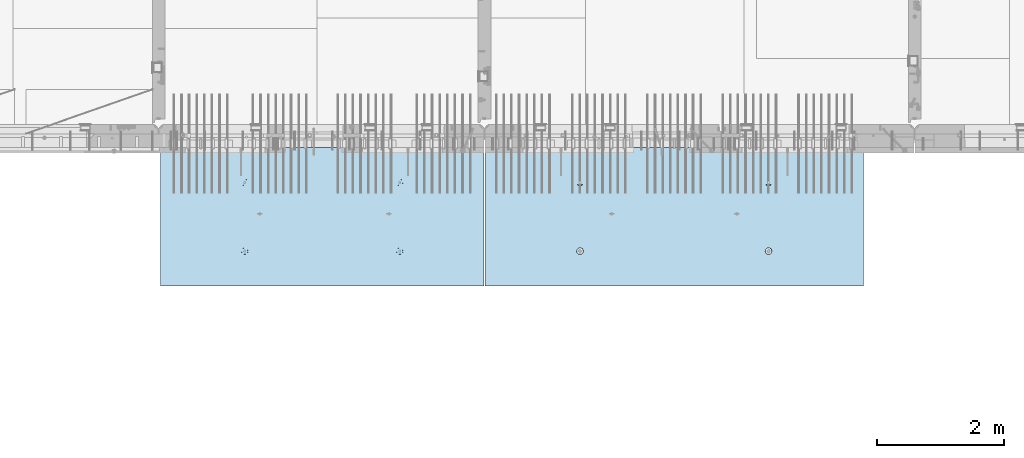
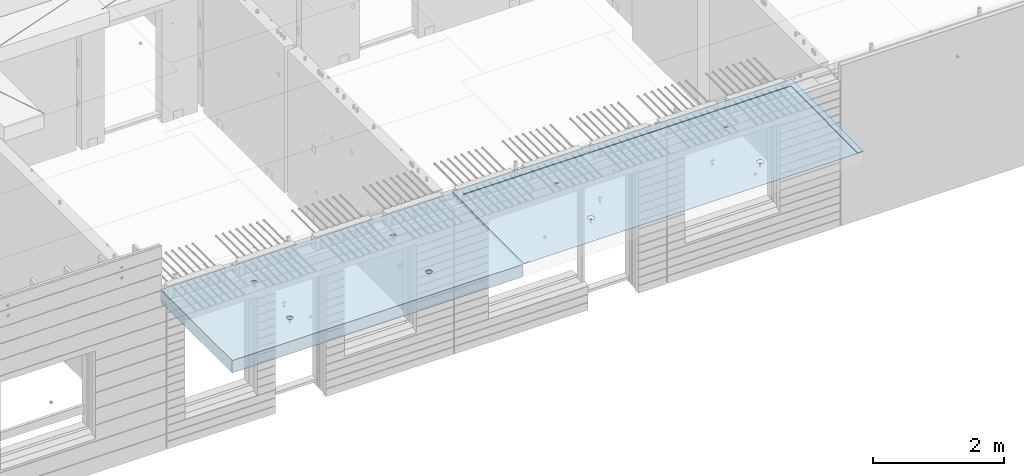
# One storey, part 173 of 309: 2 slabs, 2 elements without a shape of their own.
"""IFC2X3 building model written with IfcOpenShell, lengths in millimetres."""

from ifc_helpers import new_model, si_unit, frame, origin_with_axes, place, context, subcontext, project, spatial, faceted_brep, material, type_object, element, aggregate, save


model = new_model("IFC2X3")

# Units and contexts
model_context = context("Model", 3, precision=1e-05, world=origin_with_axes())
body_context = subcontext(model_context, "Body", "Model", "MODEL_VIEW")
ifc_project = project(units=[si_unit("LENGTHUNIT", "METRE", prefix="MILLI"), si_unit("AREAUNIT", "SQUARE_METRE"), si_unit("VOLUMEUNIT", "CUBIC_METRE"), si_unit("MASSUNIT", "GRAM", prefix="KILO"), si_unit("TIMEUNIT", "SECOND"), si_unit("PLANEANGLEUNIT", "RADIAN"), si_unit("SOLIDANGLEUNIT", "STERADIAN"), si_unit("THERMODYNAMICTEMPERATUREUNIT", "DEGREE_CELSIUS"), si_unit("LUMINOUSINTENSITYUNIT", "LUMEN")], contexts=[model_context])

# Site, building, storey
site_placement = place(None, origin_with_axes())
site = spatial("IfcSite", under=ifc_project, at=site_placement, CompositionType="ELEMENT")
building_placement = place(site_placement, origin_with_axes())
building = spatial("IfcBuilding", under=site, at=building_placement, CompositionType="ELEMENT")
storey_placement = place(building_placement, origin_with_axes())
storey = spatial("IfcBuildingStorey", under=building, at=storey_placement, Name="7", CompositionType="ELEMENT", Elevation=0.0)

# Assembly, slab
assembly_1_placement = place(storey_placement, origin_with_axes())
assembly_1 = element("IfcElementAssembly", 1, at=assembly_1_placement, inside=storey, AssemblyPlace="NOTDEFINED", PredefinedType="REINFORCEMENT_UNIT")
ifc_material = material(Name="CONCRETE/C35/45")
slab_type_1 = type_object("IfcSlabType", PredefinedType="NOTDEFINED")
slab_1_placement = place(assembly_1_placement, frame((21819.9998568014, 7630.00344031289, 102715.0), z_axis=(-1.11800000013248e-06, -0.999999999999375, 0.0), x_axis=(0.999999999999375, -1.11799999997436e-06, 0.0)))
slab_1 = element("IfcSlab", 2, at=slab_1_placement, type_object=slab_type_1, material=ifc_material, PredefinedType="FLOOR", context=body_context, shape_type="Brep", body=[
    faceted_brep([(5979.99951171875, -15.0, 2184.99365234375), (5980.0, -15.0, -9.11677489057183e-09), (5979.99999999881, 14.9999889254686, 0.00267301795884123), (5979.99951171875, -5.00001158128725, 2184.99365234375), (0.0, -15.0, 0.0), (0.0, 15.0, 0.0), (-0.000976578216068447, -15.0, 2184.99365234375), (-0.000976578216068447, -4.99999962141737, 2184.99365234375), (99.9990234070356, -15.0, 2184.99365234375), (99.9990234170364, -4.9999998214189, 2184.99365234375), (100.000169136605, 4.99999899105751, 149.999887195343), (100.000169145234, 13.6270007889543, 149.999887195343), (5880.00017319752, 4.99999608613143, 150.00314992553), (5880.00017320615, 13.626982615926, 150.003149916904), (5879.99902340611, -15.0, 2184.99365234375), (5879.99902341611, -5.00001138128573, 2184.99365234375), (1542.35643735858, -9.29224814563349, 1604.231780609), (1541.83170276904, -15.0, 1604.6130235213), (1549.1758082776, -15.0, 1619.02660112956), (1549.7771641149, -9.43573199193634, 1618.8312080139), (1530.78185465163, -9.17831515427679, 1592.6391402674), (1530.39300293862, -15.0, 1593.17435002456), (1516.18640918342, -9.10513605941378, 1585.19319237956), (1515.97940842387, -15.0, 1585.83027769861), (1500.00182150668, -9.07991502917139, 1582.62695858894), (1500.001822281, -15.0, 1583.29969551145), (1483.81723975291, -9.10513649972563, 1585.19322968407), (1484.02424196357, -15.0, 1585.830314479), (1469.22181146578, -9.17831599155033, 1592.63921119998), (1469.61066435491, -15.0, 1593.17441998503), (1457.64725549508, -9.29224929746124, 1604.23187818621), (1458.17199085636, -15.0, 1604.61311981363), (1450.22656238703, -9.43573334516259, 1618.83132264417), (1450.82791852787, -15.0, 1619.02671432798), (1447.68309567355, -9.59468214913795, 1635.00430118441), (1448.29733633842, -15.0, 1635.00430047201), (1450.2609443985, -9.75352120940806, 1651.16611452994), (1450.82795530481, -15.0, 1650.98188079173), (1457.70289734829, -9.8967179244064, 1665.7363264415), (1458.17206081124, -15.0, 1665.39545840293), (1469.27747998517, -10.0102960024233, 1677.29285448863), (1469.61076064166, -15.0, 1676.8341319033), (1483.85169912509, -10.0831879667385, 1684.70958694994), (1484.02435515854, -15.0, 1684.17820423219), (1500.00194194467, -10.1082993235468, 1687.2646615023), (1500.00194130486, -15.0, 1686.70878642047), (1516.15217889783, -10.0831875282893, 1684.70954981947), (1515.97952162574, -15.0, 1684.17816745179), (1530.72638100472, -10.0102951681765, 1677.29278383764), (1530.39309923654, -15.0, 1676.83406194283), (1542.30093708833, -9.89671677560546, 1665.73622914589), (1541.8317727351, -15.0, 1665.3953621106), (1549.74285653791, -9.75351985805901, 1651.16600007372), (1549.17584506145, -15.0, 1650.98176759331), (1552.32066807389, -9.59468072727032, 1635.00418074657), (1551.70642724745, -15.0, 1635.00418144815), (4522.3564410818, -9.29220762521436, 1604.22834792249), (4521.83170276706, -15.0, 1604.6095935413), (4529.17580827563, -15.0, 1619.02317114956), (4529.77716849079, -9.43569148414826, 1618.82777661145), (4510.78185735683, -9.17827462384594, 1592.63570656128), (4510.39300293665, -15.0, 1593.17092004456), (4496.18641060492, -9.10509552253643, 1585.18975801856), (4495.9794084219, -15.0, 1585.8268477186), (4480.0018215047, -9.0798744900676, 1582.62352400222), (4480.00182227903, -15.0, 1583.29626553145), (4463.81723832746, -9.10509596284828, 1585.18979532306), (4464.0242419616, -15.0, 1585.826884499), (4449.22180875662, -9.17827546110493, 1592.63577749387), (4449.61066435294, -15.0, 1593.17099000503), (4437.64725176791, -9.29220877704211, 1604.2284454997), (4438.17199085438, -15.0, 1604.60968983363), (4430.22655800719, -9.43569283735997, 1618.82789124172), (4430.82791852589, -15.0, 1619.02328434798), (4427.68309107, -9.59464165531972, 1635.00087120442), (4428.29733633644, -15.0, 1635.00087049201), (4430.26094002169, -9.75348072955967, 1651.16268597142), (4430.82795530284, -15.0, 1650.97845081173), (4437.70289362601, -9.89667745715997, 1665.73289916447), (4438.17206080927, -15.0, 1665.39202842292), (4449.27747728091, -10.0102555451595, 1677.28942822802), (4449.61076063968, -15.0, 1676.8307019233), (4463.85169770267, -10.0831475158775, 1684.70616134165), (4464.02435515657, -15.0, 1684.17477425219), (4480.00194194271, -10.1082588749123, 1687.26123611873), (4480.00194130289, -15.0, 1686.70535644047), (4496.15218031632, -10.0831470774283, 1684.70612421118), (4495.97952162377, -15.0, 1684.17473747179), (4510.72638370505, -10.0102547109127, 1677.28935757703), (4510.39309923456, -15.0, 1676.83063196283), (4522.30094080667, -9.89667630834447, 1665.73280186885), (4521.83177273312, -15.0, 1665.3919321306), (4529.74286091078, -9.75347937821061, 1651.16257151518), (4529.17584505948, -15.0, 1650.97833761331), (4532.32067267349, -9.59464023343753, 1635.00075076656), (4531.70642724547, -15.0, 1635.00075146815), (1548.20188836927, -15.0, 534.342642348693), (1549.93108139027, 1.00000001621083, 533.780791293159), (1542.47398964419, 1.00000003085006, 519.145466335593), (1541.00305088176, -15.0, 520.214168473346), (1530.85930981639, 1.00000004246249, 507.530813244751), (1529.79061104799, -15.0, 509.001754452365), (1516.22396769263, 1.00000004991307, 500.073755189214), (1515.66212060056, -15.0, 501.802949491101), (1500.00057253043, 1.00000005248876, 497.504240967835), (1500.00057462316, -15.0, 499.322422775775), (1483.77718328329, 1.00000004991307, 500.073792535463), (1484.33903435596, -15.0, 501.802985543973), (1469.14185832572, 1.00000004246249, 507.530884281538), (1470.21056048023, -15.0, 509.001823029003), (1457.52720523488, 1.00000003085006, 519.145564109342), (1458.99814645746, -15.0, 520.214262860991), (1450.07014717934, 1.00000001621083, 533.780906233094), (1451.79934149372, -15.0, 534.342753308024), (1447.50063295797, 0.999999999985448, 550.004301395301), (1449.31881477614, -15.0, 550.004299286574), (1450.07018452559, 0.999999983760063, 566.227690642441), (1451.7993775432, -15.0, 565.66583955601), (4521.00305087978, -15.0, 520.210738493346), (4509.79061104602, -15.0, 508.998324472365), (4495.66212059859, -15.0, 501.799519511101), (4480.00057462119, -15.0, 499.318992795775), (4464.33903435399, -15.0, 501.799555563973), (4450.21056047825, -15.0, 508.998393049003), (4438.99814645549, -15.0, 520.210832880991), (4431.79934149174, -15.0, 534.339323328024), (4429.31881477417, -15.0, 550.000869306574), (4431.79937754123, -15.0, 565.66240957601), (4438.99821502665, -15.0, 579.790883454235), (4450.21065486042, -15.0, 591.003297478775), (4464.33914530993, -15.0, 598.20210244292), (4480.00069129073, -15.0, 600.682629159347), (4495.66223156131, -15.0, 598.202066390048), (4509.79070543914, -15.0, 591.003228902137), (4521.0031194619, -15.0, 579.79078906659), (4528.20192442356, -15.0, 565.662298616679), (4530.68245113774, -15.0, 550.000752637028), (4528.2018883673, -15.0, 534.339212368693), (1458.99821502862, -15.0, 579.794313434235), (1470.21065486239, -15.0, 591.006727458775), (1484.33914531191, -15.0, 598.20553242292), (1500.0006912927, -15.0, 600.686059139346), (1515.66223156328, -15.0, 598.205496370048), (1529.79070544112, -15.0, 591.006658882137), (1541.00311946388, -15.0, 579.79421904659), (1548.20192442553, -15.0, 565.665728596678), (1550.68245113972, -15.0, 550.004182617028), (1542.47406068098, 0.999999969120836, 580.862917826261), (1549.93111873652, 0.999999983760063, 566.227575702506), (1552.5006329579, 0.999999999985448, 550.004180540301), (1457.52727627167, 0.999999969120836, 580.86301560001), (1469.1652247598, 0.651633722678525, 592.445642049598), (1483.79210013919, 0.578478401774191, 599.889170954462), (1500.000693327, 0.553276318343706, 602.453476918547), (1516.20928062719, 0.578478841795004, 599.889133689844), (1530.83613891201, 0.65163455993752, 592.445571143348), (4496.20928204567, 0.578519292655983, 599.885708081553), (4480.00069332503, 0.553316766978242, 602.450051534984), (4463.79209871677, 0.578518852620618, 599.885745346174), (4449.16522205553, 0.651674179942347, 592.442215788989), (4437.52727626969, 0.999999969120836, 580.85958562001), (4522.474060679, 0.999999969120836, 580.859487846261), (4510.83614161234, 0.651675017215894, 592.442144882733), (4529.93111873454, 0.999999983760063, 566.224145722506), (4430.07018452362, 0.999999983760063, 566.224260662441), (4427.50063295599, 0.999999999985448, 550.000871415301), (4437.52720523291, 1.00000003085006, 519.142134129342), (4430.07014717737, 1.00000001621083, 533.777476253094), (4449.14185832375, 1.00000004246249, 507.527454301538), (4463.77718328132, 1.00000004991307, 500.070362555463), (4480.00057252846, 1.00000005248876, 497.500810987835), (4496.22396769066, 1.00000004991307, 500.070325209214), (4510.85930981442, 1.00000004246249, 507.527383264751), (4522.47398964222, 1.00000003085006, 519.142036355593), (4529.9310813883, 1.00000001621083, 533.777361313159), (4532.50063295592, 0.999999999985448, 550.000750560301)], [[[0, 1, 2, 3]], [[1, 4, 5, 2]], [[4, 6, 7, 5]], [[6, 8, 9, 7]], [[8, 10, 11, 9]], [[10, 12, 13, 11]], [[12, 14, 15, 13]], [[2, 5, 7, 9, 11, 13, 15, 3]], [[14, 0, 3, 15]], [[16, 17, 18, 19]], [[20, 21, 17, 16]], [[22, 23, 21, 20]], [[24, 25, 23, 22]], [[26, 27, 25, 24]], [[28, 29, 27, 26]], [[29, 28, 30, 31]], [[31, 30, 32, 33]], [[33, 32, 34, 35]], [[35, 34, 36, 37]], [[37, 36, 38, 39]], [[39, 38, 40, 41]], [[41, 40, 42, 43]], [[43, 42, 44, 45]], [[45, 44, 46, 47]], [[48, 49, 47, 46]], [[50, 51, 49, 48]], [[52, 53, 51, 50]], [[54, 55, 53, 52]], [[19, 18, 55, 54]], [[56, 57, 58, 59]], [[60, 61, 57, 56]], [[62, 63, 61, 60]], [[64, 65, 63, 62]], [[66, 67, 65, 64]], [[68, 69, 67, 66]], [[69, 68, 70, 71]], [[71, 70, 72, 73]], [[73, 72, 74, 75]], [[75, 74, 76, 77]], [[77, 76, 78, 79]], [[79, 78, 80, 81]], [[81, 80, 82, 83]], [[83, 82, 84, 85]], [[85, 84, 86, 87]], [[88, 89, 87, 86]], [[90, 91, 89, 88]], [[92, 93, 91, 90]], [[94, 95, 93, 92]], [[59, 58, 95, 94]], [[96, 97, 98, 99]], [[99, 98, 100, 101]], [[101, 100, 102, 103]], [[103, 102, 104, 105]], [[105, 104, 106, 107]], [[107, 106, 108, 109]], [[109, 108, 110, 111]], [[111, 110, 112, 113]], [[113, 112, 114, 115]], [[115, 114, 116, 117]], [[6, 4, 1, 0, 14, 8], [118, 119, 120, 121, 122, 123, 124, 125, 126, 127, 128, 129, 130, 131, 132, 133, 134, 135, 136, 137], [99, 101, 103, 105, 107, 109, 111, 113, 115, 117, 138, 139, 140, 141, 142, 143, 144, 145, 146, 96], [57, 61, 63, 65, 67, 69, 71, 73, 75, 77, 79, 81, 83, 85, 87, 89, 91, 93, 95, 58], [17, 21, 23, 25, 27, 29, 31, 33, 35, 37, 39, 41, 43, 45, 47, 49, 51, 53, 55, 18]], [[144, 147, 148, 145]], [[145, 148, 149, 146]], [[96, 146, 149, 97]], [[148, 147, 150, 116, 114, 112, 110, 108, 106, 104, 102, 100, 98, 97, 149]], [[117, 116, 150, 138]], [[138, 150, 151, 139]], [[139, 151, 152, 140]], [[140, 152, 153, 141]], [[154, 142, 141, 153]], [[155, 143, 142, 154]], [[147, 144, 143, 155]], [[14, 12, 10, 8], [156, 157, 158, 159, 160, 161, 162], [154, 153, 152, 151, 150, 147, 155], [90, 88, 86, 84, 82, 80, 78, 76, 74, 72, 70, 68, 66, 64, 62, 60, 56, 59, 94, 92], [50, 48, 46, 44, 42, 40, 38, 36, 34, 32, 30, 28, 26, 24, 22, 20, 16, 19, 54, 52]], [[134, 161, 163, 135]], [[161, 134, 133, 162]], [[162, 133, 132, 156]], [[156, 132, 131, 157]], [[130, 158, 157, 131]], [[129, 159, 158, 130]], [[128, 160, 159, 129]], [[127, 164, 160, 128]], [[126, 165, 164, 127]], [[124, 166, 167, 125]], [[123, 168, 166, 124]], [[122, 169, 168, 123]], [[121, 170, 169, 122]], [[120, 171, 170, 121]], [[119, 172, 171, 120]], [[118, 173, 172, 119]], [[137, 174, 173, 118]], [[163, 161, 160, 164, 165, 167, 166, 168, 169, 170, 171, 172, 173, 174, 175]], [[137, 136, 175, 174]], [[135, 163, 175, 136]], [[125, 167, 165, 126]]]),
])
aggregate(assembly_1, [slab_1])

assembly_2_placement = place(storey_placement, origin_with_axes())
assembly_2 = element("IfcElementAssembly", 3, at=assembly_2_placement, inside=storey, AssemblyPlace="NOTDEFINED", PredefinedType="REINFORCEMENT_UNIT")
slab_type_2 = type_object("IfcSlabType", PredefinedType="NOTDEFINED")
slab_2_placement = place(assembly_2_placement, frame((21799.9998568133, 7629.99655735226, 102585.0), z_axis=(-1.11800000013248e-06, -0.999999999999375, 0.0), x_axis=(-0.999999999999093, 1.34699999998405e-06, 0.0)))
slab_2 = element("IfcSlab", 4, at=slab_2_placement, type_object=slab_type_2, material=ifc_material, PredefinedType="FLOOR", context=body_context, shape_type="Brep", body=[
    faceted_brep([(5044.99621029956, 114.99969472253, 2129.9941778127), (5049.99621029291, 104.999717756495, 2129.9969343719), (5050.00056912109, 104.999718373161, 2124.99413742958), (5050.00056237491, 114.999718304491, 2129.99413740084), (5054.99621302712, 114.999716839098, 2129.99684687227), (5054.97949706663, 114.989962399486, 59.9968469627447), (5049.97949433241, 104.989963316897, 59.9969344623751), (5044.97949436115, 114.989963248227, 59.9969277161954), (5044.99612954588, 114.99969387379, 2119.99417510723), (1345.44871152677, -100.0, 1587.44807086476), (1359.38711485626, -100.0, 1594.5500657358), (1370.44868706042, -100.0, 1605.61166773987), (1377.55064438139, -100.0, 1619.5500902021), (1379.99779775433, -100.0, 1635.00094321718), (1377.5506027568, -100.0, 1650.45178963957), (1370.44860788575, -100.0, 1664.39019296907), (1359.38700588168, -100.0, 1675.45176517322), (1345.44858341946, -100.0, 1682.55372249419), (1329.99773040438, -100.0, 1685.00087586713), (1314.54688398198, -100.0, 1682.5536808696), (1300.60848065249, -100.0, 1675.45168599855), (1289.54690844832, -100.0, 1664.39008399448), (1282.44495112737, -100.0, 1650.45166153225), (1279.99779775442, -100.0, 1635.00080851718), (1282.44499275196, -100.0, 1619.54996209479), (1289.546987623, -100.0, 1605.61155876528), (1300.60858962707, -100.0, 1594.54998656113), (1314.5470120893, -100.0, 1587.44802924017), (1329.99786510437, -100.0, 1585.00087586722), (1280.8238743996, -115.0, 1619.023226398), (1278.29325229988, -115.0, 1635.00080622115), (1288.16798273216, -115.0, 1604.60965022772), (1299.60668480455, -115.0, 1593.17097897115), (1314.02028075981, -115.0, 1585.82690946879), (1329.9978674004, -115.0, 1583.29633041268), (1345.97544722355, -115.0, 1585.8269525124), (1360.38902339383, -115.0, 1593.17106084496), (1371.8276946504, -115.0, 1604.60976291735), (1379.17176415276, -115.0, 1619.02335887261), (1381.70234320887, -115.0, 1635.0009455132), (1379.17172110915, -115.0, 1650.97852533635), (1371.82761277659, -115.0, 1665.39210150663), (1360.3889107042, -115.0, 1676.8307727632), (1345.97531474894, -115.0, 1684.17484226556), (1329.99772810835, -115.0, 1686.70542132167), (1314.0201482852, -115.0, 1684.17479922195), (1299.60657211492, -115.0, 1676.83069088939), (1288.16790085835, -115.0, 1665.391988817), (1280.82383135599, -115.0, 1650.97839286174), (1345.45017302177, -110.0, 502.44807086574), (1359.38857635127, -110.0, 509.550065736787), (1370.45014855542, -110.0, 520.611667740858), (1377.55210587639, -110.0, 534.550090203084), (1379.99925924933, -110.0, 550.000943218161), (1377.5520642518, -110.0, 565.45178964055), (1370.45006938075, -110.0, 579.390192970052), (1359.38846737668, -110.0, 590.451765174208), (1345.45004491446, -110.0, 597.55372249517), (1329.99919189938, -110.0, 600.000875868115), (1314.54834547699, -110.0, 597.55368087058), (1300.60994214749, -110.0, 590.451685999535), (1289.54836994332, -110.0, 579.390083995463), (1282.44641262237, -110.0, 565.451661533237), (1279.99925924942, -110.0, 550.000808518161), (1282.44645424696, -110.0, 534.549962095771), (1289.548449118, -110.0, 520.611558766269), (1300.61005112208, -110.0, 509.549986562113), (1314.5484735843, -110.0, 502.448029241151), (1329.99932659938, -110.0, 500.000875868206), (1281.90608146284, -115.0, 534.374383530176), (1279.43107743124, -115.0, 550.000807752819), (1289.08878082105, -115.0, 520.277589253747), (1300.2760828479, -115.0, 509.090317365454), (1314.37289647447, -115.0, 501.907655984027), (1329.99932736472, -115.0, 499.432694050024), (1345.62575158736, -115.0, 501.907698081623), (1359.72254586379, -115.0, 509.09039743984), (1370.90981775208, -115.0, 520.277699466684), (1378.09247913351, -115.0, 534.374513093253), (1380.56744106751, -115.0, 550.000943983501), (1378.09243703591, -115.0, 565.627368206145), (1370.9097376777, -115.0, 579.724162482574), (1359.72243565085, -115.0, 590.911434370867), (1345.62562202428, -115.0, 598.094095752294), (1329.99919113403, -115.0, 600.569057686296), (1314.37276691139, -115.0, 598.094053654699), (1300.27597263497, -115.0, 590.911354296481), (1289.08870074667, -115.0, 579.724052269637), (1281.90603936524, -115.0, 565.627238643067), (3795.44871152455, -100.0, 1587.45137101476), (3809.38711485404, -100.0, 1594.5533658858), (3820.4486870582, -100.0, 1605.61496788987), (3827.55064437916, -100.0, 1619.5533903521), (3829.99779775211, -100.0, 1635.00424336718), (3827.55060275457, -100.0, 1650.45508978957), (3820.44860788353, -100.0, 1664.39349311907), (3809.38700587945, -100.0, 1675.45506532322), (3795.44858341723, -100.0, 1682.55702264419), (3779.99773040215, -100.0, 1685.00417601713), (3764.54688397976, -100.0, 1682.5569810196), (3750.60848065026, -100.0, 1675.45498614855), (3739.5469084461, -100.0, 1664.39338414448), (3732.44495112514, -100.0, 1650.45496168225), (3729.9977977522, -100.0, 1635.00410866718), (3732.44499274973, -100.0, 1619.55326224479), (3739.54698762078, -100.0, 1605.61485891528), (3750.60858962485, -100.0, 1594.55328671113), (3764.54701208707, -100.0, 1587.45132939017), (3779.99786510215, -100.0, 1585.00417601722), (3730.82387439738, -115.0, 1619.026526548), (3728.29325229766, -115.0, 1635.00410637115), (3738.16798272993, -115.0, 1604.61295037772), (3749.60668480233, -115.0, 1593.17427912115), (3764.02028075758, -115.0, 1585.83020961879), (3779.99786739818, -115.0, 1583.29963056268), (3795.97544722132, -115.0, 1585.8302526624), (3810.38902339161, -115.0, 1593.17436099496), (3821.82769464818, -115.0, 1604.61306306735), (3829.17176415053, -115.0, 1619.02665902261), (3831.70234320665, -115.0, 1635.0042456632), (3829.17172110693, -115.0, 1650.98182548635), (3821.82761277437, -115.0, 1665.39540165663), (3810.38891070198, -115.0, 1676.8340729132), (3795.97531474672, -115.0, 1684.17814241556), (3779.99772810613, -115.0, 1686.70872147167), (3764.02014828298, -115.0, 1684.17809937195), (3749.6065721127, -115.0, 1676.83399103939), (3738.16790085613, -115.0, 1665.395288967), (3730.82383135377, -115.0, 1650.98169301174), (3795.45017301955, -110.0, 502.45137101574), (3809.38857634904, -110.0, 509.553365886786), (3820.4501485532, -110.0, 520.614967890858), (3827.55210587417, -110.0, 534.553390353083), (3829.99925924711, -110.0, 550.00424336816), (3827.55206424958, -110.0, 565.455089790549), (3820.45006937853, -110.0, 579.393493120052), (3809.38846737445, -110.0, 590.455065324208), (3795.45004491224, -110.0, 597.557022645169), (3779.99919189715, -110.0, 600.004176018115), (3764.54834547476, -110.0, 597.55698102058), (3750.60994214526, -110.0, 590.454986149534), (3739.54836994111, -110.0, 579.393384145463), (3732.44641262015, -110.0, 565.454961683236), (3729.9992592472, -110.0, 550.00410866816), (3732.44645424473, -110.0, 534.55326224577), (3739.54844911578, -110.0, 520.614858916269), (3750.61005111985, -110.0, 509.553286712113), (3764.54847358208, -110.0, 502.45132939115), (3779.99932659715, -110.0, 500.004176018206), (3731.90608146061, -115.0, 534.377683680175), (3729.43107742902, -115.0, 550.00410790282), (3739.08878081883, -115.0, 520.280889403746), (3750.27608284568, -115.0, 509.093617515454), (3764.37289647224, -115.0, 501.910956134026), (3779.99932736249, -115.0, 499.435994200024), (3795.62575158514, -115.0, 501.910998231622), (3809.72254586156, -115.0, 509.093697589839), (3820.90981774986, -115.0, 520.280999616683), (3828.09247913129, -115.0, 534.377813243253), (3830.56744106529, -115.0, 550.004244133502), (3828.09243703369, -115.0, 565.630668356144), (3820.90973767548, -115.0, 579.727462632573), (3809.72243564863, -115.0, 590.914734520867), (3795.62562202206, -115.0, 598.097395902294), (3779.99919113181, -115.0, 600.572357836296), (3764.37276690917, -115.0, 598.097353804698), (3750.27597263274, -115.0, 590.914654446481), (3739.08870074445, -115.0, 579.727352419636), (3731.90603936302, -115.0, 565.630538793067), (5110.0, -115.0, -1.47338141687214e-10), (5110.00048828125, -115.0, 2184.99365234375), (0.000232655722356867, -115.0, 2184.99365234375), (7.27595761418343e-12, -115.0, 0.0), (7.27595761418343e-12, 115.0, 0.0), (5110.0, 115.0, -1.47338141687214e-10), (5110.00048828125, 115.0, 2184.99365234375), (0.000232655722356867, 115.0, 2184.99365234375), (60.0005625930098, 114.97620397943, 2130.03443336377), (60.0005693391904, 104.976204048085, 2125.03443339252), (60.000481839561, 114.976203130689, 2120.0344306583)], [[[0, 1, 2]], [[3, 4, 1, 0]], [[5, 6, 2, 1, 4]], [[7, 6, 5]], [[8, 2, 6, 7]], [[9, 10, 11, 12, 13, 14, 15, 16, 17, 18, 19, 20, 21, 22, 23, 24, 25, 26, 27, 28]], [[29, 24, 23, 30]], [[31, 25, 24, 29]], [[32, 26, 25, 31]], [[33, 27, 26, 32]], [[34, 28, 27, 33]], [[35, 9, 28, 34]], [[36, 10, 9, 35]], [[37, 11, 10, 36]], [[38, 12, 11, 37]], [[39, 13, 12, 38]], [[40, 14, 13, 39]], [[41, 15, 14, 40]], [[42, 16, 15, 41]], [[43, 17, 16, 42]], [[44, 18, 17, 43]], [[45, 19, 18, 44]], [[46, 20, 19, 45]], [[47, 21, 20, 46]], [[48, 22, 21, 47]], [[30, 23, 22, 48]], [[49, 50, 51, 52, 53, 54, 55, 56, 57, 58, 59, 60, 61, 62, 63, 64, 65, 66, 67, 68]], [[69, 64, 63, 70]], [[71, 65, 64, 69]], [[72, 66, 65, 71]], [[73, 67, 66, 72]], [[74, 68, 67, 73]], [[75, 49, 68, 74]], [[76, 50, 49, 75]], [[77, 51, 50, 76]], [[78, 52, 51, 77]], [[79, 53, 52, 78]], [[80, 54, 53, 79]], [[81, 55, 54, 80]], [[82, 56, 55, 81]], [[83, 57, 56, 82]], [[84, 58, 57, 83]], [[85, 59, 58, 84]], [[86, 60, 59, 85]], [[87, 61, 60, 86]], [[88, 62, 61, 87]], [[70, 63, 62, 88]], [[89, 90, 91, 92, 93, 94, 95, 96, 97, 98, 99, 100, 101, 102, 103, 104, 105, 106, 107, 108]], [[109, 104, 103, 110]], [[111, 105, 104, 109]], [[112, 106, 105, 111]], [[113, 107, 106, 112]], [[114, 108, 107, 113]], [[115, 89, 108, 114]], [[116, 90, 89, 115]], [[117, 91, 90, 116]], [[118, 92, 91, 117]], [[119, 93, 92, 118]], [[120, 94, 93, 119]], [[121, 95, 94, 120]], [[122, 96, 95, 121]], [[123, 97, 96, 122]], [[124, 98, 97, 123]], [[125, 99, 98, 124]], [[126, 100, 99, 125]], [[127, 101, 100, 126]], [[128, 102, 101, 127]], [[110, 103, 102, 128]], [[129, 130, 131, 132, 133, 134, 135, 136, 137, 138, 139, 140, 141, 142, 143, 144, 145, 146, 147, 148]], [[149, 144, 143, 150]], [[151, 145, 144, 149]], [[152, 146, 145, 151]], [[153, 147, 146, 152]], [[154, 148, 147, 153]], [[155, 129, 148, 154]], [[156, 130, 129, 155]], [[157, 131, 130, 156]], [[158, 132, 131, 157]], [[159, 133, 132, 158]], [[160, 134, 133, 159]], [[161, 135, 134, 160]], [[162, 136, 135, 161]], [[163, 137, 136, 162]], [[164, 138, 137, 163]], [[165, 139, 138, 164]], [[166, 140, 139, 165]], [[167, 141, 140, 166]], [[168, 142, 141, 167]], [[150, 143, 142, 168]], [[169, 170, 171, 172], [167, 166, 165, 164, 163, 162, 161, 160, 159, 158, 157, 156, 155, 154, 153, 152, 151, 149, 150, 168], [127, 126, 125, 124, 123, 122, 121, 120, 119, 118, 117, 116, 115, 114, 113, 112, 111, 109, 110, 128], [87, 86, 85, 84, 83, 82, 81, 80, 79, 78, 77, 76, 75, 74, 73, 72, 71, 69, 70, 88], [47, 46, 45, 44, 43, 42, 41, 40, 39, 38, 37, 36, 35, 34, 33, 32, 31, 29, 30, 48]], [[169, 172, 173, 174]], [[170, 169, 174, 175]], [[171, 170, 175, 176]], [[172, 171, 176, 173]], [[177, 178, 179]], [[178, 177, 0, 2]], [[179, 178, 2, 8]], [[175, 174, 173, 176], [4, 3, 0, 177, 179, 8, 7, 5]]]),
])
aggregate(assembly_2, [slab_2])

save(model, "model.ifc")
